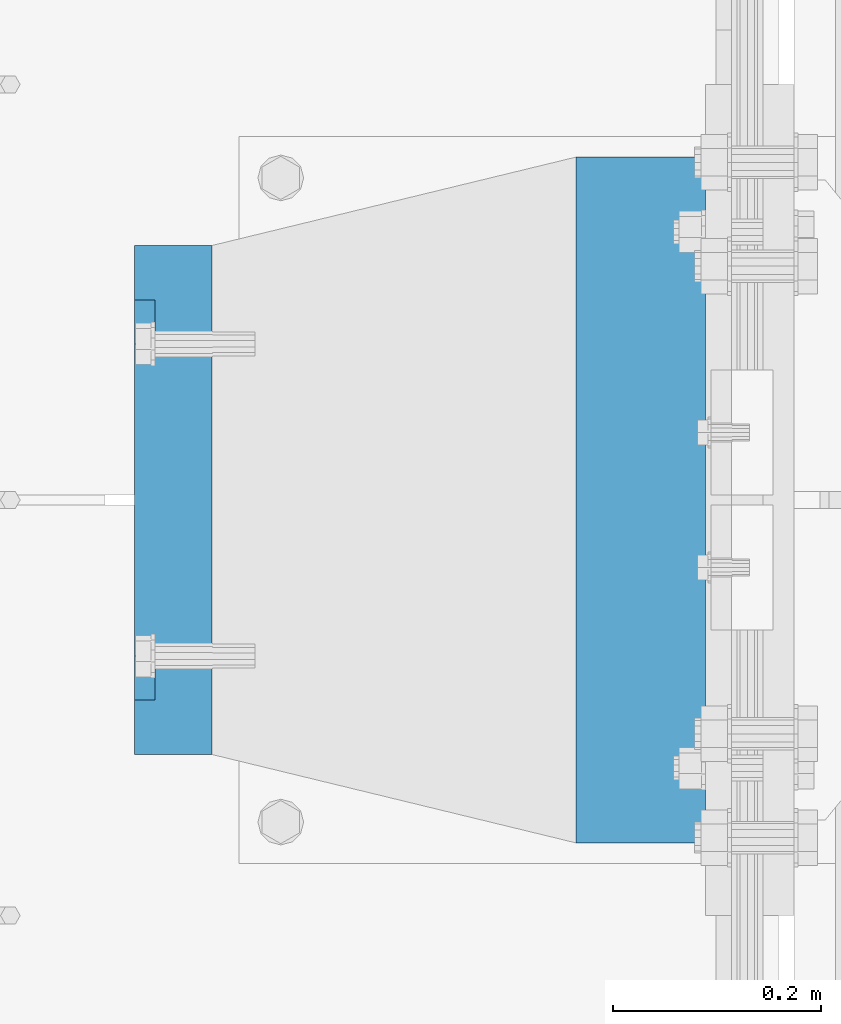
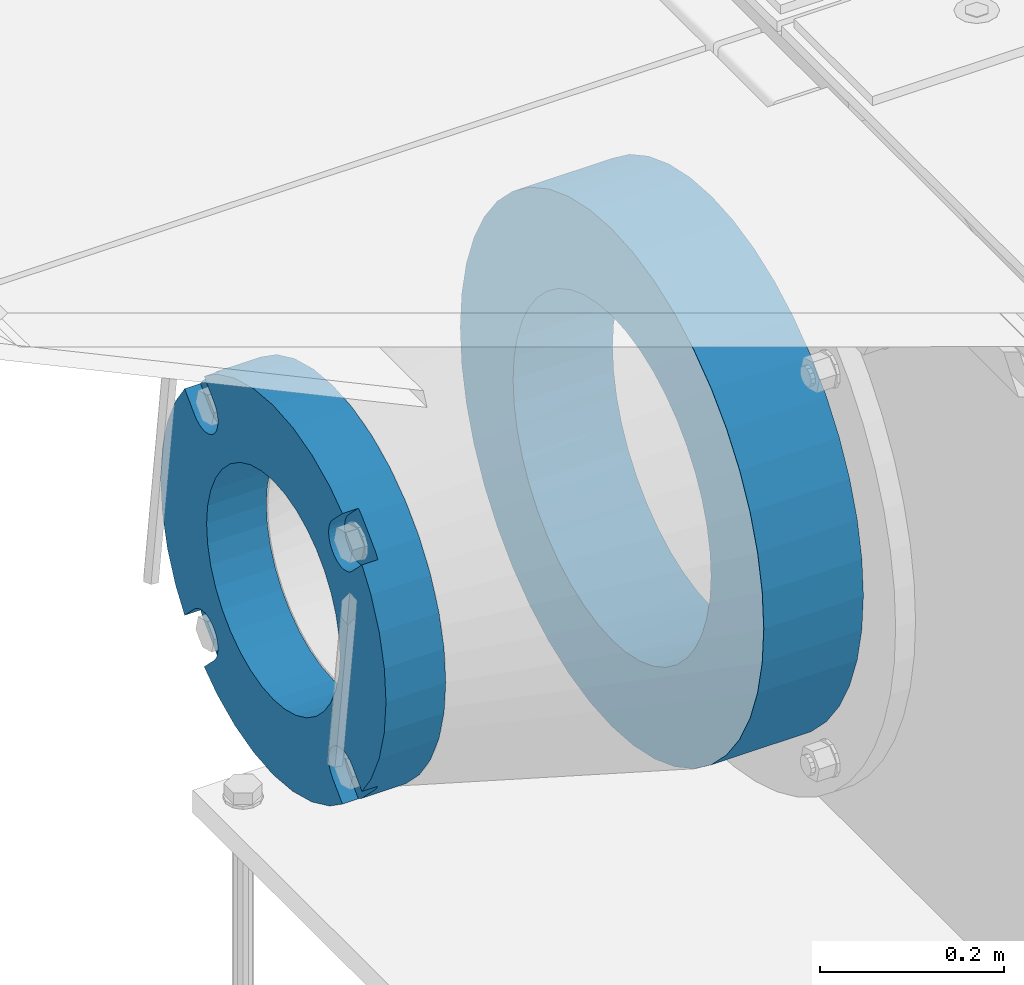
# One storey, part 143 of 240: 2 beams.
"""IFC2X3 building model written with IfcOpenShell, lengths in millimetres."""

import ifcopenshell
import ifcopenshell.guid

model = None  # the IFC model being written
_history = None  # IfcOwnerHistory: only IFC2X3 demands one
_inside = {}  # id of a spatial element -> (the spatial element, [elements in it])
_under = {}  # id of a project, library or spatial element -> (it, [spatial elements below it])
_declared = {}  # id of a project -> (the project, [libraries it declares])
_typed = {}  # id of a type object -> (the type object, [elements of that type])
_made_of = {}  # id of a material, layer set ... -> (it, [elements and type objects made of it])


def new_model(schema):
    """Start an empty IFC model of exactly this schema.

    Asked for "IFC4X3", IfcOpenShell would pick the latest addendum, in which some entities
    have other attributes; the version numbers below select the first issue.
    IFC2X3 requires an IfcOwnerHistory on every rooted entity: one is made here for all.
    """
    global model, _history
    if schema == "IFC4X3":
        model = ifcopenshell.file(schema_version=(4, 3, 0, 0))
    else:
        model = ifcopenshell.file(schema=schema)
    _inside.clear()
    _under.clear()
    _declared.clear()
    _typed.clear()
    _made_of.clear()
    _history = None
    if model.schema == "IFC2X3":
        org = make("IfcOrganization", Name="unknown")
        user = make(
            "IfcPersonAndOrganization",
            ThePerson=make("IfcPerson", FamilyName="unknown"),
            TheOrganization=org,
        )
        app = make(
            "IfcApplication",
            ApplicationDeveloper=org,
            Version="unknown",
            ApplicationFullName="unknown",
            ApplicationIdentifier="unknown",
        )
        _history = make(
            "IfcOwnerHistory",
            OwningUser=user,
            OwningApplication=app,
            ChangeAction="ADDED",
            CreationDate=0,
        )
    return model


def make(cls, **values):
    """One entity of the class cls with the attributes given. An attribute that is None is left unset."""
    return model.create_entity(
        cls, **{name: value for name, value in values.items() if value is not None}
    )


def rooted(cls, **values):
    """An entity with a GlobalId (a new one), such as an element, a storey or a relation."""
    return make(cls, GlobalId=ifcopenshell.guid.new(), OwnerHistory=_history, **values)


def si_unit(unit_type, name, prefix=None):
    """IfcSIUnit, for example si_unit("LENGTHUNIT", "METRE", prefix="MILLI")."""
    return make("IfcSIUnit", UnitType=unit_type, Prefix=prefix, Name=name)


def assignment(units):
    """IfcUnitAssignment: the units of a project."""
    return None if units is None else make("IfcUnitAssignment", Units=units)


def point(xyz):
    """IfcCartesianPoint."""
    return None if xyz is None else make("IfcCartesianPoint", Coordinates=xyz)


def direction(xyz):
    """IfcDirection."""
    return None if xyz is None else make("IfcDirection", DirectionRatios=xyz)


def frame(location, z_axis=None, x_axis=None):
    """IfcAxis2Placement3D, a coordinate frame: its origin and axes. An axis left out is left unset."""
    return make(
        "IfcAxis2Placement3D",
        Location=point(location),
        Axis=direction(z_axis),
        RefDirection=direction(x_axis),
    )


def origin_with_axes():
    """The frame at (0, 0, 0) with the z axis (0, 0, 1) and the x axis (1, 0, 0) written out."""
    return frame((0.0, 0.0, 0.0), z_axis=(0.0, 0.0, 1.0), x_axis=(1.0, 0.0, 0.0))


def place(relative_to, where):
    """IfcLocalPlacement: puts the frame where relative to a parent placement (None: the world)."""
    return make(
        "IfcLocalPlacement", PlacementRelTo=relative_to, RelativePlacement=where
    )


def context(
    kind, dimensions, precision=None, world=None, true_north=None, identifier=None
):
    """IfcGeometricRepresentationContext, for example the 3D "Model" context."""
    return make(
        "IfcGeometricRepresentationContext",
        ContextIdentifier=identifier,
        ContextType=kind,
        CoordinateSpaceDimension=dimensions,
        Precision=precision,
        WorldCoordinateSystem=world,
        TrueNorth=true_north,
    )


def subcontext(parent, identifier, kind, view, scale=None):
    """IfcGeometricRepresentationSubContext, for example "Body" below "Model"."""
    return make(
        "IfcGeometricRepresentationSubContext",
        ContextIdentifier=identifier,
        ContextType=kind,
        ParentContext=parent,
        TargetScale=scale,
        TargetView=view,
    )


def project(units=None, contexts=None):
    """IfcProject with its units and contexts."""
    return rooted(
        "IfcProject",
        Name="project",
        RepresentationContexts=contexts,
        UnitsInContext=assignment(units),
    )


def spatial(cls, under=None, at=None, **own):
    """A site, building, storey or space (cls), placed at a placement, below another one or the project."""
    s = rooted(cls, ObjectPlacement=at, **own)
    if under is not None:
        _under.setdefault(under.id(), (under, []))[1].append(s)
    return s


def faces_of(points, faces, orient=None, outer=None):
    """IfcFace entities. A face is a list of loops; a loop is a list of indices into points, from 0.

    orient and outer hold one flag for each loop. By default every Orientation is true, the
    first loop of a face is its IfcFaceOuterBound and the others are IfcFaceBound.
    """
    made = []
    for i, loops in enumerate(faces):
        bounds = []
        for j, loop in enumerate(loops):
            is_outer = j == 0 if outer is None else outer[i][j]
            bounds.append(
                make(
                    "IfcFaceOuterBound" if is_outer else "IfcFaceBound",
                    Bound=make("IfcPolyLoop", Polygon=[points[k] for k in loop]),
                    Orientation=True if orient is None else orient[i][j],
                )
            )
        made.append(make("IfcFace", Bounds=bounds))
    return made


def faceted_brep(points, faces, orient=None, outer=None, voids=None):
    """IfcFacetedBrep: a solid bounded by flat faces; with voids (closed shells), ...WithVoids."""
    shared = [point(p) for p in points]
    hull = make("IfcClosedShell", CfsFaces=faces_of(shared, faces, orient, outer))
    if voids is None:
        return make("IfcFacetedBrep", Outer=hull)
    return make(
        "IfcFacetedBrepWithVoids",
        Outer=hull,
        Voids=[
            make(cls, CfsFaces=faces_of(shared, fs, o, b)) for cls, fs, o, b in voids
        ],
    )


def shape(context_of_items, identifier, shape_type, items):
    """IfcShapeRepresentation: the items that make up one representation, for example the "Body"."""
    return make(
        "IfcShapeRepresentation",
        ContextOfItems=context_of_items,
        RepresentationIdentifier=identifier,
        RepresentationType=shape_type,
        Items=items,
    )


def material(Name=None, Category=None):
    """IfcMaterial."""
    return make("IfcMaterial", Name=Name, Category=Category)


def made_of(thing, what):
    """Note that an element or type object is made of a material, layer set ...; save() writes the relation."""
    if what is not None:
        _made_of.setdefault(what.id(), (what, []))[1].append(thing)
    return thing


def type_object(cls, material=None, **own):
    """A type object (cls), such as IfcWallType, which elements share."""
    return made_of(rooted(cls, **own), material)


def element(
    cls,
    number,
    at=None,
    inside=None,
    cuts=None,
    type_object=None,
    material=None,
    context=None,
    identifier="Body",
    shape_type=None,
    held_by="IfcProductDefinitionShape",
    body=None,
    shapes=None,
    **own,
):
    """One element of the class cls, such as IfcWall. Its Tag is "e" and its number.

    at: its placement. inside: the storey or other place that contains it. cuts: it is an
    opening in that element (IfcRelVoidsElement). A single representation is given by context,
    identifier, shape_type and body (its items); several are given by shapes. held_by: the class
    of the entity that holds the representations. save() writes the other relations.
    """
    e = rooted(cls, Tag="e%d" % number, ObjectPlacement=at, **own)
    if body is not None:
        shapes = [shape(context, identifier, shape_type, body)]
    if shapes is not None:
        e.Representation = make(held_by, Representations=shapes)
    if inside is not None:
        _inside.setdefault(inside.id(), (inside, []))[1].append(e)
    if cuts is not None:
        rooted(
            "IfcRelVoidsElement", RelatingBuildingElement=cuts, RelatedOpeningElement=e
        )
    if type_object is not None:
        _typed.setdefault(type_object.id(), (type_object, []))[1].append(e)
    return made_of(e, material)


def aggregate(whole, parts):
    """IfcRelAggregates: a whole, such as a stair, and the parts it consists of."""
    return rooted("IfcRelAggregates", RelatingObject=whole, RelatedObjects=parts)


def save(model, path):
    """Write the relations noted so far, then the file.

    IfcRelAggregates (storeys below a building ...), IfcRelContainedInSpatialStructure (elements
    in a storey), IfcRelDefinesByType, IfcRelAssociatesMaterial and IfcRelDeclares: one each for
    every whole, place, type object, material and project.
    """
    for whole, parts in _under.values():
        aggregate(whole, parts)
    for where, things in _inside.values():
        rooted(
            "IfcRelContainedInSpatialStructure",
            RelatedElements=things,
            RelatingStructure=where,
        )
    for kind, things in _typed.values():
        rooted("IfcRelDefinesByType", RelatedObjects=things, RelatingType=kind)
    for what, things in _made_of.values():
        rooted("IfcRelAssociatesMaterial", RelatedObjects=things, RelatingMaterial=what)
    for by, libraries in _declared.values():
        rooted("IfcRelDeclares", RelatingContext=by, RelatedDefinitions=libraries)
    model.write(path)


model = new_model("IFC2X3")

# Units and contexts
model_context = context("Model", 3, precision=1e-05, world=origin_with_axes())
body_context = subcontext(model_context, "Body", "Model", "MODEL_VIEW")
ifc_project = project(units=[si_unit("LENGTHUNIT", "METRE", prefix="MILLI"), si_unit("AREAUNIT", "SQUARE_METRE"), si_unit("VOLUMEUNIT", "CUBIC_METRE"), si_unit("MASSUNIT", "GRAM", prefix="KILO"), si_unit("TIMEUNIT", "SECOND"), si_unit("PLANEANGLEUNIT", "RADIAN"), si_unit("SOLIDANGLEUNIT", "STERADIAN"), si_unit("THERMODYNAMICTEMPERATUREUNIT", "DEGREE_CELSIUS"), si_unit("LUMINOUSINTENSITYUNIT", "LUMEN")], contexts=[model_context])

# Site, building, storey
site_placement = place(None, origin_with_axes())
site = spatial("IfcSite", under=ifc_project, at=site_placement, CompositionType="ELEMENT")
building_placement = place(site_placement, origin_with_axes())
building = spatial("IfcBuilding", under=site, at=building_placement, Name="Standard", CompositionType="ELEMENT")
storey_placement = place(building_placement, origin_with_axes())
storey = spatial("IfcBuildingStorey", under=building, at=storey_placement, Name="Undefined", CompositionType="ELEMENT", Elevation=0.0)

# Beams
ifc_material_1 = material(Name="SCN-500-E2")
beam_type_1 = type_object("IfcBeamType", PredefinedType="NOTDEFINED")
beam_1_placement = place(storey_placement, frame((41900.0, 33000.0000014662, -515.0), z_axis=(0.0, 0.0, 1.0), x_axis=(-1.0, 0.0, 0.0)))
element("IfcBeam", 1, at=beam_1_placement, inside=storey, type_object=beam_type_1, material=ifc_material_1, context=body_context, shape_type="Brep", body=[
    faceted_brep([(75.0, 192.717024793295, -150.290616455866), (75.0, 171.473395903973, -129.046987566545), (55.0, 171.473395903973, -129.046987566545), (55.0, 192.717024793288, -150.290616455862), (75.0, 167.467485559311, -125.685629673395), (55.0, 167.467485559311, -125.685629673395), (75.0, 162.938740320955, -123.070957391003), (55.0, 162.938740320955, -123.070957391003), (75.0, 158.024763821777, -121.282416213472), (55.0, 158.024763821777, -121.282416213472), (75.0, 152.874864751095, -120.374350059435), (55.0, 152.874864751095, -120.374350059435), (75.0, 147.645520186205, -120.374350059479), (55.0, 147.645520186205, -120.374350059479), (75.0, 142.495621115537, -121.282416213595), (55.0, 142.495621115537, -121.282416213595), (75.0, 137.581644616374, -123.070957391204), (55.0, 137.581644616374, -123.070957391204), (75.0, 133.052899378039, -125.685629673665), (55.0, 133.052899378039, -125.685629673665), (75.0, 129.04698903278, -129.046987566545), (55.0, 129.04698903278, -129.046987566545), (75.0, 125.685631139982, -133.05289791162), (55.0, 125.685631139982, -133.05289791162), (75.0, 123.070958857592, -137.581643149926), (55.0, 123.070958857592, -137.581643149926), (75.0, 121.28241768005, -142.49561964906), (55.0, 121.28241768005, -142.49561964906), (75.0, 120.374351525992, -147.64551871968), (55.0, 120.374351525992, -147.64551871968), (75.0, 120.374351525999, -152.874863284513), (55.0, 120.374351525999, -152.874863284513), (75.0, 121.282417680093, -158.024762355132), (55.0, 121.282417680093, -158.024762355132), (75.0, 123.070958857665, -162.938738854251), (55.0, 123.070958857665, -162.938738854251), (75.0, 125.685631140077, -167.467484092545), (55.0, 125.685631140077, -167.467484092545), (75.0, 129.04698903278, -171.473394437738), (55.0, 129.04698903278, -171.473394437738), (55.0, 150.290618180639, -192.717023585594), (75.0, 150.290618180639, -192.717023585596), (55.0, 157.482964373201, -187.68088856415), (55.0, 187.680888564151, -157.482964373202), (75.0, -192.717023585596, 150.290618180639), (75.0, -171.4733929715, 129.046987566545), (55.0, -171.4733929715, 129.046987566545), (55.0, -192.717023585596, 150.290618180638), (75.0, -167.467482626838, 125.685629673395), (55.0, -167.467482626838, 125.685629673395), (75.0, -162.938737388482, 123.070957391003), (55.0, -162.938737388482, 123.070957391003), (75.0, -158.024760889304, 121.282416213472), (55.0, -158.024760889304, 121.282416213472), (75.0, -152.874861818622, 120.374350059435), (55.0, -152.874861818622, 120.374350059435), (75.0, -147.645517253732, 120.374350059479), (55.0, -147.645517253732, 120.374350059479), (75.0, -142.495618183064, 121.282416213595), (55.0, -142.495618183064, 121.282416213595), (75.0, -137.581641683901, 123.070957391204), (55.0, -137.581641683901, 123.070957391204), (75.0, -133.052896445566, 125.685629673665), (55.0, -133.052896445566, 125.685629673665), (75.0, -129.046986100308, 129.046987566545), (55.0, -129.046986100308, 129.046987566545), (75.0, -125.68562820751, 133.05289791162), (55.0, -125.68562820751, 133.05289791162), (75.0, -123.070955925119, 137.581643149926), (55.0, -123.070955925119, 137.581643149926), (75.0, -121.282414747577, 142.49561964906), (55.0, -121.282414747577, 142.49561964906), (75.0, -120.374348593519, 147.64551871968), (55.0, -120.374348593519, 147.64551871968), (75.0, -120.374348593527, 152.874863284513), (55.0, -120.374348593527, 152.874863284513), (75.0, -121.28241474762, 158.024762355132), (55.0, -121.28241474762, 158.024762355132), (75.0, -123.070955925192, 162.938738854251), (55.0, -123.070955925192, 162.938738854251), (75.0, -125.685628207604, 167.467484092545), (55.0, -125.685628207604, 167.467484092545), (75.0, -129.046986100308, 171.473394437738), (55.0, -129.046986100308, 171.473394437738), (55.0, -150.290616455866, 192.717024793292), (75.0, -150.290616455866, 192.717024793295), (75.0, 150.290618180639, 192.717023585596), (75.0, 129.04698903278, 171.473394437739), (55.0, 129.04698903278, 171.473394437739), (55.0, 150.290618180632, 192.717023585593), (75.0, 125.685631139633, 167.467484093078), (55.0, 125.685631139633, 167.467484093078), (75.0, 123.070958857235, 162.938738854723), (55.0, 123.070958857235, 162.938738854723), (75.0, 121.282417679708, 158.024762355545), (55.0, 121.282417679708, 158.024762355545), (75.0, 120.374351525672, 152.874863284862), (55.0, 120.374351525672, 152.874863284862), (75.0, 120.374351525716, 147.645518719972), (55.0, 120.374351525716, 147.645518719972), (75.0, 121.282417679831, 142.495619649306), (55.0, 121.282417679831, 142.495619649306), (75.0, 123.070958857439, 137.581643150138), (55.0, 123.070958857439, 137.581643150138), (75.0, 125.685631139902, 133.052897911806), (55.0, 125.685631139902, 133.052897911806), (75.0, 129.04698903278, 129.046987566546), (55.0, 129.04698903278, 129.046987566546), (75.0, 133.052899377857, 125.685629673749), (55.0, 133.052899377857, 125.685629673749), (75.0, 137.581644616163, 123.070957391354), (55.0, 137.581644616163, 123.070957391354), (75.0, 142.495621115297, 121.282416213815), (55.0, 142.495621115297, 121.282416213815), (75.0, 147.645520185913, 120.374350059761), (55.0, 147.645520185913, 120.374350059761), (75.0, 152.874864750745, 120.374350059768), (55.0, 152.874864750745, 120.374350059768), (75.0, 158.02476382137, 121.282416213859), (55.0, 158.02476382137, 121.282416213859), (75.0, 162.938740320489, 123.070957391429), (55.0, 162.938740320489, 123.070957391429), (75.0, 167.46748555878, 125.685629673842), (55.0, 167.46748555878, 125.685629673842), (75.0, 171.473395903973, 129.046987566546), (55.0, 171.473395903973, 129.046987566546), (55.0, 192.717024793288, 150.290616455864), (75.0, 192.717024793295, 150.290616455871), (0.0, 212.176223927185, -122.5), (0.0, 230.224692092546, -83.7949351147888), (75.0, 230.224692092546, -83.7949351147888), (75.0, 212.176223927185, -122.5), (0.0, 241.277899487992, -42.5438035283978), (75.0, 241.277899487992, -42.5438035283978), (0.0, 245.0, 0.0), (75.0, 245.0, 0.0), (0.0, 241.277899487992, 42.543803528398), (75.0, 241.277899487992, 42.543803528398), (0.0, 230.224692092546, 83.7949351147889), (75.0, 230.224692092546, 83.7949351147889), (0.0, 212.176223927185, 122.5), (75.0, 212.176223927185, 122.5), (0.0, 187.680888564151, 157.482964373202), (55.0, 187.680888564151, 157.482964373202), (0.0, 157.482964373201, 187.68088856415), (55.0, 157.482964373201, 187.68088856415), (0.0, 122.5, 212.176223927187), (75.0, 122.5, 212.176223927187), (0.0, 83.7949351147909, 230.224692092548), (75.0, 83.7949351147909, 230.224692092548), (0.0, 42.5438035283951, 241.277899487991), (75.0, 42.5438035283951, 241.277899487991), (0.0, 0.0, 245.0), (75.0, 0.0, 245.0), (0.0, -42.5438035283951, 241.277899487991), (75.0, -42.5438035283951, 241.277899487991), (0.0, -83.7949351147909, 230.224692092548), (75.0, -83.7949351147909, 230.224692092548), (0.0, -122.5, 212.176223927187), (75.0, -122.5, 212.176223927187), (0.0, -157.482964373201, 187.68088856415), (55.0, -157.482964373201, 187.68088856415), (0.0, -187.680888564151, 157.482964373202), (55.0, -187.680888564151, 157.482964373202), (0.0, -212.176223927185, 122.5), (75.0, -212.176223927185, 122.5), (0.0, -230.224692092546, 83.7949351147888), (75.0, -230.224692092546, 83.7949351147888), (0.0, -241.277899487992, 42.5438035283979), (75.0, -241.277899487992, 42.5438035283979), (0.0, -245.0, 0.0), (75.0, -245.0, 0.0), (0.0, -187.680888564151, -157.482964373202), (0.0, -157.482964373201, -187.68088856415), (55.0, -157.482964373201, -187.68088856415), (55.0, -187.680888564151, -157.482964373202), (0.0, 83.7949351147909, -230.224692092547), (0.0, 122.5, -212.176223927187), (75.0, 122.5, -212.176223927187), (75.0, 83.7949351147909, -230.224692092547), (0.0, 42.5438035283951, -241.277899487991), (75.0, 42.5438035283951, -241.277899487991), (0.0, 0.0, -245.0), (75.0, 0.0, -245.0), (0.0, -42.5438035283951, -241.277899487991), (75.0, -42.5438035283951, -241.277899487991), (0.0, -83.7949351147909, -230.224692092548), (75.0, -83.7949351147909, -230.224692092548), (0.0, -122.5, -212.176223927187), (75.0, -122.5, -212.176223927187), (75.0, -150.290616455866, -192.717024793295), (55.0, -150.290616455866, -192.717024793296), (55.0, -129.046986100308, -171.473394437739), (55.0, -125.68562820716, -167.467484093078), (55.0, -123.070955924763, -162.938738854723), (55.0, -121.282414747235, -158.024762355545), (55.0, -120.374348593199, -152.874863284861), (55.0, -120.374348593243, -147.645518719972), (55.0, -121.282414747358, -142.495619649306), (55.0, -123.070955924966, -137.581643150138), (55.0, -125.68562820743, -133.052897911806), (55.0, -129.046986100308, -129.046987566546), (55.0, -133.052896445384, -125.685629673749), (55.0, -137.58164168369, -123.070957391354), (55.0, -142.495618182824, -121.282416213815), (55.0, -147.645517253441, -120.374350059761), (55.0, -152.874861818273, -120.374350059768), (55.0, -158.024760888897, -121.282416213859), (55.0, -162.938737388016, -123.070957391429), (55.0, -167.467482626307, -125.685629673842), (55.0, -171.4733929715, -129.046987566546), (55.0, -192.717023585596, -150.290618180638), (75.0, -129.046986100308, -171.473394437739), (75.0, -125.68562820716, -167.467484093078), (75.0, -123.070955924763, -162.938738854723), (75.0, -121.282414747235, -158.024762355545), (75.0, -120.374348593199, -152.874863284861), (75.0, -120.374348593243, -147.645518719972), (75.0, -121.282414747358, -142.495619649306), (75.0, -123.070955924966, -137.581643150138), (75.0, -125.68562820743, -133.052897911806), (75.0, -129.046986100308, -129.046987566546), (75.0, -133.052896445384, -125.685629673749), (75.0, -137.58164168369, -123.070957391354), (75.0, -142.495618182824, -121.282416213815), (75.0, -147.645517253441, -120.374350059761), (75.0, -152.874861818273, -120.374350059768), (75.0, -158.024760888897, -121.282416213859), (75.0, -162.938737388016, -123.070957391429), (75.0, -167.467482626307, -125.685629673842), (75.0, -171.4733929715, -129.046987566546), (75.0, -192.717023585596, -150.29061818064), (75.0, -212.176223927185, -122.5), (0.0, -212.176223927185, -122.5), (0.0, -230.224692092546, -83.794935114789), (75.0, -230.224692092546, -83.794935114789), (0.0, -241.277899487992, -42.5438035283979), (75.0, -241.277899487992, -42.5438035283979), (0.0, 187.680888564151, -157.482964373202), (0.0, 157.482964373201, -187.68088856415), (0.0, -142.797124186771, -25.1789857617049), (0.0, -136.25543001396, -49.592920782222), (0.0, -125.573683548741, -72.5), (0.0, -111.076444252249, -93.2042034045483), (0.0, -93.2042034045517, -111.076444252252), (0.0, -72.5, -125.573683548744), (0.0, -49.5929207822192, -136.255430013957), (0.0, -25.1789857617041, -142.79712418677), (0.0, 0.0, -145.0), (0.0, 25.1789857617041, -142.79712418677), (0.0, 49.5929207822192, -136.255430013957), (0.0, 72.5, -125.573683548744), (0.0, 93.2042034045517, -111.076444252252), (0.0, 111.076444252249, -93.2042034045483), (0.0, 125.573683548741, -72.5), (0.0, 136.25543001396, -49.592920782222), (0.0, 142.797124186771, -25.178985761705), (0.0, 145.0, 0.0), (0.0, 142.797124186771, 25.1789857617048), (0.0, 136.25543001396, 49.5929207822219), (0.0, 125.573683548741, 72.4999999999999), (0.0, 111.076444252249, 93.2042034045482), (0.0, 93.2042034045517, 111.076444252252), (0.0, 72.5, 125.573683548744), (0.0, 49.5929207822192, 136.255430013957), (0.0, 25.1789857617041, 142.79712418677), (0.0, 0.0, 145.0), (0.0, -25.1789857617041, 142.79712418677), (0.0, -49.5929207822192, 136.255430013957), (0.0, -72.5, 125.573683548744), (0.0, -93.2042034045517, 111.076444252252), (0.0, -111.076444252249, 93.2042034045483), (0.0, -125.573683548741, 72.5000000000001), (0.0, -136.25543001396, 49.5929207822221), (0.0, -142.797124186771, 25.1789857617049), (0.0, -145.0, 0.0), (75.0, -145.0, 0.0), (75.0, -142.797124186771, -25.1789857617049), (75.0, -136.25543001396, -49.592920782222), (75.0, -125.573683548741, -72.5), (75.0, -111.076444252249, -93.2042034045483), (75.0, -93.2042034045517, -111.076444252252), (75.0, -72.5, -125.573683548744), (75.0, -49.5929207822192, -136.255430013957), (75.0, -25.1789857617041, -142.79712418677), (75.0, 0.0, -145.0), (75.0, 25.1789857617041, -142.79712418677), (75.0, 49.5929207822192, -136.255430013957), (75.0, 72.5, -125.573683548744), (75.0, 93.2042034045517, -111.076444252252), (75.0, 111.076444252249, -93.2042034045483), (75.0, 125.573683548741, -72.5), (75.0, 136.25543001396, -49.592920782222), (75.0, 142.797124186771, -25.178985761705), (75.0, 145.0, 0.0), (75.0, 142.797124186771, 25.1789857617048), (75.0, 136.25543001396, 49.5929207822219), (75.0, 125.573683548741, 72.4999999999999), (75.0, 111.076444252249, 93.2042034045482), (75.0, 93.2042034045517, 111.076444252252), (75.0, 72.5, 125.573683548744), (75.0, 49.5929207822192, 136.255430013957), (75.0, 25.1789857617041, 142.79712418677), (75.0, 0.0, 145.0), (75.0, -25.1789857617041, 142.79712418677), (75.0, -49.5929207822192, 136.255430013957), (75.0, -72.5, 125.573683548744), (75.0, -93.2042034045517, 111.076444252252), (75.0, -111.076444252249, 93.2042034045483), (75.0, -125.573683548741, 72.5000000000001), (75.0, -136.25543001396, 49.5929207822221), (75.0, -142.797124186771, 25.1789857617049)], [[[0, 1, 2, 3]], [[4, 5, 2, 1]], [[6, 7, 5, 4]], [[8, 9, 7, 6]], [[10, 11, 9, 8]], [[12, 13, 11, 10]], [[14, 15, 13, 12]], [[16, 17, 15, 14]], [[18, 19, 17, 16]], [[20, 21, 19, 18]], [[22, 23, 21, 20]], [[24, 25, 23, 22]], [[26, 27, 25, 24]], [[28, 29, 27, 26]], [[30, 31, 29, 28]], [[32, 33, 31, 30]], [[34, 35, 33, 32]], [[36, 37, 35, 34]], [[38, 39, 37, 36]], [[40, 39, 38, 41]], [[42, 43, 3, 2, 5, 7, 9, 11, 13, 15, 17, 19, 21, 23, 25, 27, 29, 31, 33, 35, 37, 39, 40]], [[44, 45, 46, 47]], [[48, 49, 46, 45]], [[50, 51, 49, 48]], [[52, 53, 51, 50]], [[54, 55, 53, 52]], [[56, 57, 55, 54]], [[58, 59, 57, 56]], [[60, 61, 59, 58]], [[62, 63, 61, 60]], [[64, 65, 63, 62]], [[66, 67, 65, 64]], [[68, 69, 67, 66]], [[70, 71, 69, 68]], [[72, 73, 71, 70]], [[74, 75, 73, 72]], [[76, 77, 75, 74]], [[78, 79, 77, 76]], [[80, 81, 79, 78]], [[82, 83, 81, 80]], [[84, 83, 82, 85]], [[86, 87, 88, 89]], [[90, 91, 88, 87]], [[92, 93, 91, 90]], [[94, 95, 93, 92]], [[96, 97, 95, 94]], [[98, 99, 97, 96]], [[100, 101, 99, 98]], [[102, 103, 101, 100]], [[104, 105, 103, 102]], [[106, 107, 105, 104]], [[108, 109, 107, 106]], [[110, 111, 109, 108]], [[112, 113, 111, 110]], [[114, 115, 113, 112]], [[116, 117, 115, 114]], [[118, 119, 117, 116]], [[120, 121, 119, 118]], [[122, 123, 121, 120]], [[124, 125, 123, 122]], [[126, 125, 124, 127]], [[128, 129, 130, 131]], [[129, 132, 133, 130]], [[132, 134, 135, 133]], [[134, 136, 137, 135]], [[136, 138, 139, 137]], [[138, 140, 141, 139]], [[127, 141, 140, 142, 143, 126]], [[142, 144, 145, 143]], [[89, 88, 91, 93, 95, 97, 99, 101, 103, 105, 107, 109, 111, 113, 115, 117, 119, 121, 123, 125, 126, 143, 145]], [[144, 146, 147, 86, 89, 145]], [[146, 148, 149, 147]], [[148, 150, 151, 149]], [[150, 152, 153, 151]], [[152, 154, 155, 153]], [[154, 156, 157, 155]], [[156, 158, 159, 157]], [[85, 159, 158, 160, 161, 84]], [[160, 162, 163, 161]], [[47, 46, 49, 51, 53, 55, 57, 59, 61, 63, 65, 67, 69, 71, 73, 75, 77, 79, 81, 83, 84, 161, 163]], [[162, 164, 165, 44, 47, 163]], [[164, 166, 167, 165]], [[166, 168, 169, 167]], [[168, 170, 171, 169]], [[172, 173, 174, 175]], [[176, 177, 178, 179]], [[180, 176, 179, 181]], [[182, 180, 181, 183]], [[184, 182, 183, 185]], [[186, 184, 185, 187]], [[188, 186, 187, 189]], [[173, 188, 189, 190, 191, 174]], [[175, 174, 191, 192, 193, 194, 195, 196, 197, 198, 199, 200, 201, 202, 203, 204, 205, 206, 207, 208, 209, 210, 211]], [[190, 212, 192, 191]], [[213, 193, 192, 212]], [[214, 194, 193, 213]], [[215, 195, 194, 214]], [[216, 196, 195, 215]], [[217, 197, 196, 216]], [[218, 198, 197, 217]], [[219, 199, 198, 218]], [[220, 200, 199, 219]], [[221, 201, 200, 220]], [[222, 202, 201, 221]], [[223, 203, 202, 222]], [[224, 204, 203, 223]], [[225, 205, 204, 224]], [[226, 206, 205, 225]], [[227, 207, 206, 226]], [[228, 208, 207, 227]], [[229, 209, 208, 228]], [[230, 210, 209, 229]], [[211, 210, 230, 231]], [[232, 233, 172, 175, 211, 231]], [[234, 233, 232, 235]], [[236, 234, 235, 237]], [[170, 236, 237, 171]], [[168, 166, 164, 162, 160, 158, 156, 154, 152, 150, 148, 146, 144, 142, 140, 138, 136, 134, 132, 129, 128, 238, 239, 177, 176, 180, 182, 184, 186, 188, 173, 172, 233, 234, 236, 170], [240, 241, 242, 243, 244, 245, 246, 247, 248, 249, 250, 251, 252, 253, 254, 255, 256, 257, 258, 259, 260, 261, 262, 263, 264, 265, 266, 267, 268, 269, 270, 271, 272, 273, 274, 275]], [[240, 275, 276, 277]], [[241, 240, 277, 278]], [[242, 241, 278, 279]], [[243, 242, 279, 280]], [[244, 243, 280, 281]], [[245, 244, 281, 282]], [[246, 245, 282, 283]], [[247, 246, 283, 284]], [[248, 247, 284, 285]], [[249, 248, 285, 286]], [[250, 249, 286, 287]], [[251, 250, 287, 288]], [[252, 251, 288, 289]], [[253, 252, 289, 290]], [[254, 253, 290, 291]], [[255, 254, 291, 292]], [[256, 255, 292, 293]], [[257, 256, 293, 294]], [[258, 257, 294, 295]], [[259, 258, 295, 296]], [[260, 259, 296, 297]], [[261, 260, 297, 298]], [[262, 261, 298, 299]], [[263, 262, 299, 300]], [[264, 263, 300, 301]], [[265, 264, 301, 302]], [[266, 265, 302, 303]], [[267, 266, 303, 304]], [[268, 267, 304, 305]], [[269, 268, 305, 306]], [[270, 269, 306, 307]], [[271, 270, 307, 308]], [[272, 271, 308, 309]], [[273, 272, 309, 310]], [[274, 273, 310, 311]], [[275, 274, 311, 276]], [[24, 22, 20, 18, 16, 14, 12, 10, 8, 6, 4, 1, 0, 131, 130, 133, 135, 137, 139, 141, 127, 124, 122, 120, 118, 116, 114, 112, 110, 108, 106, 104, 102, 100, 98, 96, 94, 92, 90, 87, 86, 147, 149, 151, 153, 155, 157, 159, 85, 82, 80, 78, 76, 74, 72, 70, 68, 66, 64, 62, 60, 58, 56, 54, 52, 50, 48, 45, 44, 165, 167, 169, 171, 237, 235, 232, 231, 230, 229, 228, 227, 226, 225, 224, 223, 222, 221, 220, 219, 218, 217, 216, 215, 214, 213, 212, 190, 189, 187, 185, 183, 181, 179, 178, 41, 38, 36, 34, 32, 30, 28, 26], [310, 309, 308, 307, 306, 305, 304, 303, 302, 301, 300, 299, 298, 297, 296, 295, 294, 293, 292, 291, 290, 289, 288, 287, 286, 285, 284, 283, 282, 281, 280, 279, 278, 277, 276, 311]], [[238, 128, 131, 0, 3, 43]], [[239, 238, 43, 42]], [[178, 177, 239, 42, 40, 41]]]),
])
ifc_material_2 = material(Name="STEEL/S355N")
beam_type_2 = type_object("IfcBeamType", PredefinedType="NOTDEFINED")
beam_2_placement = place(storey_placement, frame((42375.0, 33000.0, -515.0), z_axis=(0.0, 0.0, 1.0), x_axis=(-1.0, 0.0, 0.0)))
element("IfcBeam", 2, at=beam_2_placement, inside=storey, type_object=beam_type_2, material=ifc_material_2, context=body_context, shape_type="Brep", body=[
    faceted_brep([(0.0, -215.0, 0.0), (0.0, -212.811610004399, 30.5976902287563), (125.0, -212.811610004399, 30.5976902287563), (125.0, -215.0, 0.0), (0.0, -206.290989327113, 60.5724997209074), (125.0, -206.290989327113, 60.5724997209074), (0.0, -195.570879001221, 89.3142277954056), (125.0, -195.570879001221, 89.3142277954056), (0.0, -180.869509558703, 116.237775752953), (125.0, -180.869509558703, 116.237775752953), (0.0, -162.486158486165, 140.795057798236), (125.0, -162.486158486165, 140.795057798236), (0.0, -140.795057798234, 162.486158486165), (125.0, -140.795057798234, 162.486158486165), (0.0, -116.237775752954, 180.869509558704), (125.0, -116.237775752954, 180.869509558704), (0.0, -89.314227795403, 195.570879001222), (125.0, -89.314227795403, 195.570879001222), (0.0, -60.5724997209109, 206.290989327117), (125.0, -60.5724997209109, 206.290989327117), (0.0, -30.5976902287584, 212.811610004401), (125.0, -30.5976902287584, 212.811610004401), (0.0, 0.0, 215.0), (125.0, 0.0, 215.0), (0.0, 30.5976902287584, 212.811610004401), (125.0, 30.5976902287584, 212.811610004401), (0.0, 60.5724997209109, 206.290989327117), (125.0, 60.5724997209109, 206.290989327117), (0.0, 89.314227795403, 195.570879001221), (125.0, 89.314227795403, 195.570879001221), (0.0, 116.237775752954, 180.869509558704), (125.0, 116.237775752954, 180.869509558704), (0.0, 140.795057798234, 162.486158486165), (125.0, 140.795057798234, 162.486158486165), (0.0, 162.486158486165, 140.795057798236), (125.0, 162.486158486165, 140.795057798236), (0.0, 180.869509558703, 116.237775752953), (125.0, 180.869509558703, 116.237775752953), (0.0, 195.570879001221, 89.3142277954056), (125.0, 195.570879001221, 89.3142277954056), (0.0, 206.290989327113, 60.5724997209073), (125.0, 206.290989327113, 60.5724997209073), (0.0, 212.811610004399, 30.5976902287563), (125.0, 212.811610004399, 30.5976902287563), (0.0, 215.0, 0.0), (125.0, 215.0, 0.0), (0.0, 212.811610004399, -30.5976902287563), (125.0, 212.811610004399, -30.5976902287563), (0.0, 206.290989327113, -60.5724997209073), (125.0, 206.290989327113, -60.5724997209073), (0.0, 195.570879001221, -89.3142277954056), (125.0, 195.570879001221, -89.3142277954056), (0.0, 180.869509558703, -116.237775752954), (125.0, 180.869509558703, -116.237775752954), (0.0, 162.486158486165, -140.795057798236), (125.0, 162.486158486165, -140.795057798236), (0.0, 140.795057798234, -162.486158486166), (125.0, 140.795057798234, -162.486158486166), (0.0, 116.237775752954, -180.869509558704), (125.0, 116.237775752954, -180.869509558704), (0.0, 89.314227795403, -195.570879001221), (125.0, 89.314227795403, -195.570879001221), (0.0, 60.5724997209109, -206.290989327117), (125.0, 60.5724997209109, -206.290989327117), (0.0, 30.5976902287584, -212.811610004401), (125.0, 30.5976902287584, -212.811610004401), (0.0, 0.0, -215.0), (125.0, 0.0, -215.0), (0.0, -30.5976902287584, -212.811610004401), (125.0, -30.5976902287584, -212.811610004401), (0.0, -60.5724997209109, -206.290989327117), (125.0, -60.5724997209109, -206.290989327117), (0.0, -89.314227795403, -195.570879001221), (125.0, -89.314227795403, -195.570879001221), (0.0, -116.237775752954, -180.869509558704), (125.0, -116.237775752954, -180.869509558704), (0.0, -140.795057798234, -162.486158486166), (125.0, -140.795057798234, -162.486158486166), (0.0, -162.486158486165, -140.795057798236), (125.0, -162.486158486165, -140.795057798236), (0.0, -180.869509558703, -116.237775752953), (125.0, -180.869509558703, -116.237775752953), (0.0, -195.570879001221, -89.3142277954056), (125.0, -195.570879001221, -89.3142277954056), (0.0, -206.290989327113, -60.5724997209073), (125.0, -206.290989327113, -60.5724997209073), (0.0, -212.811610004399, -30.5976902287563), (125.0, -212.811610004399, -30.5976902287563), (0.0, -330.0, 0.0), (0.0, -326.641075820706, -46.9638966301842), (125.0, -326.641075820706, -46.9638966301842), (125.0, -330.0, 0.0), (0.0, -316.632681292787, -92.9717437576718), (125.0, -316.632681292787, -92.9717437576718), (0.0, -300.178558466992, -137.086954290623), (125.0, -300.178558466992, -137.086954290623), (0.0, -277.613665834288, -178.411469760347), (125.0, -277.613665834288, -178.411469760347), (0.0, -249.397359536903, -216.104042201944), (125.0, -249.397359536903, -216.104042201944), (0.0, -216.104042201943, -249.397359536905), (125.0, -216.104042201943, -249.397359536905), (0.0, -178.411469760344, -277.61366583429), (125.0, -178.411469760344, -277.61366583429), (0.0, -137.086954290622, -300.178558466991), (125.0, -137.086954290622, -300.178558466991), (0.0, -92.9717437576692, -316.632681292784), (125.0, -92.9717437576692, -316.632681292784), (0.0, -46.9638966301864, -326.641075820708), (125.0, -46.9638966301864, -326.641075820708), (0.0, 0.0, -330.0), (125.0, 0.0, -330.0), (0.0, 46.9638966301864, -326.641075820708), (125.0, 46.9638966301864, -326.641075820708), (0.0, 92.9717437576692, -316.632681292784), (125.0, 92.9717437576692, -316.632681292784), (0.0, 137.086954290622, -300.178558466991), (125.0, 137.086954290622, -300.178558466991), (0.0, 178.411469760344, -277.61366583429), (125.0, 178.411469760344, -277.61366583429), (0.0, 216.104042201943, -249.397359536905), (125.0, 216.104042201943, -249.397359536905), (0.0, 249.397359536903, -216.104042201944), (125.0, 249.397359536903, -216.104042201944), (0.0, 277.613665834288, -178.411469760347), (125.0, 277.613665834288, -178.411469760347), (0.0, 300.178558466992, -137.086954290623), (125.0, 300.178558466992, -137.086954290623), (0.0, 316.632681292787, -92.9717437576717), (125.0, 316.632681292787, -92.9717437576717), (0.0, 326.641075820706, -46.9638966301841), (125.0, 326.641075820706, -46.9638966301841), (0.0, 330.0, 0.0), (125.0, 330.0, 0.0), (0.0, 326.641075820706, 46.9638966301841), (125.0, 326.641075820706, 46.9638966301841), (0.0, 316.632681292787, 92.9717437576718), (125.0, 316.632681292787, 92.9717437576718), (0.0, 300.178558466992, 137.086954290622), (125.0, 300.178558466992, 137.086954290622), (0.0, 277.613665834288, 178.411469760347), (125.0, 277.613665834288, 178.411469760347), (0.0, 249.397359536903, 216.104042201944), (125.0, 249.397359536903, 216.104042201944), (0.0, 216.104042201943, 249.397359536905), (125.0, 216.104042201943, 249.397359536905), (0.0, 178.411469760344, 277.61366583429), (125.0, 178.411469760344, 277.61366583429), (0.0, 137.086954290622, 300.178558466991), (125.0, 137.086954290622, 300.178558466991), (0.0, 92.9717437576692, 316.632681292784), (125.0, 92.9717437576692, 316.632681292784), (0.0, 46.9638966301864, 326.641075820708), (125.0, 46.9638966301864, 326.641075820708), (0.0, 0.0, 330.0), (125.0, 0.0, 330.0), (0.0, -46.9638966301864, 326.641075820708), (125.0, -46.9638966301864, 326.641075820708), (0.0, -92.9717437576692, 316.632681292784), (125.0, -92.9717437576692, 316.632681292784), (0.0, -137.086954290622, 300.178558466991), (125.0, -137.086954290622, 300.178558466991), (0.0, -178.411469760344, 277.61366583429), (125.0, -178.411469760344, 277.61366583429), (0.0, -216.104042201943, 249.397359536905), (125.0, -216.104042201943, 249.397359536905), (0.0, -249.397359536903, 216.104042201944), (125.0, -249.397359536903, 216.104042201944), (0.0, -277.613665834288, 178.411469760347), (125.0, -277.613665834288, 178.411469760347), (0.0, -300.178558466992, 137.086954290623), (125.0, -300.178558466992, 137.086954290623), (0.0, -316.632681292787, 92.9717437576718), (125.0, -316.632681292787, 92.9717437576718), (0.0, -326.641075820706, 46.9638966301841), (125.0, -326.641075820706, 46.9638966301841)], [[[0, 1, 2, 3]], [[1, 4, 5, 2]], [[4, 6, 7, 5]], [[6, 8, 9, 7]], [[8, 10, 11, 9]], [[10, 12, 13, 11]], [[12, 14, 15, 13]], [[14, 16, 17, 15]], [[16, 18, 19, 17]], [[18, 20, 21, 19]], [[20, 22, 23, 21]], [[22, 24, 25, 23]], [[24, 26, 27, 25]], [[26, 28, 29, 27]], [[28, 30, 31, 29]], [[30, 32, 33, 31]], [[32, 34, 35, 33]], [[34, 36, 37, 35]], [[36, 38, 39, 37]], [[38, 40, 41, 39]], [[40, 42, 43, 41]], [[42, 44, 45, 43]], [[44, 46, 47, 45]], [[46, 48, 49, 47]], [[48, 50, 51, 49]], [[50, 52, 53, 51]], [[52, 54, 55, 53]], [[54, 56, 57, 55]], [[56, 58, 59, 57]], [[58, 60, 61, 59]], [[60, 62, 63, 61]], [[62, 64, 65, 63]], [[64, 66, 67, 65]], [[66, 68, 69, 67]], [[68, 70, 71, 69]], [[70, 72, 73, 71]], [[72, 74, 75, 73]], [[74, 76, 77, 75]], [[76, 78, 79, 77]], [[78, 80, 81, 79]], [[80, 82, 83, 81]], [[82, 84, 85, 83]], [[84, 86, 87, 85]], [[86, 0, 3, 87]], [[88, 89, 90, 91]], [[89, 92, 93, 90]], [[92, 94, 95, 93]], [[94, 96, 97, 95]], [[96, 98, 99, 97]], [[98, 100, 101, 99]], [[100, 102, 103, 101]], [[102, 104, 105, 103]], [[104, 106, 107, 105]], [[106, 108, 109, 107]], [[108, 110, 111, 109]], [[110, 112, 113, 111]], [[112, 114, 115, 113]], [[114, 116, 117, 115]], [[116, 118, 119, 117]], [[118, 120, 121, 119]], [[120, 122, 123, 121]], [[122, 124, 125, 123]], [[124, 126, 127, 125]], [[126, 128, 129, 127]], [[128, 130, 131, 129]], [[130, 132, 133, 131]], [[132, 134, 135, 133]], [[134, 136, 137, 135]], [[136, 138, 139, 137]], [[138, 140, 141, 139]], [[140, 142, 143, 141]], [[142, 144, 145, 143]], [[144, 146, 147, 145]], [[146, 148, 149, 147]], [[148, 150, 151, 149]], [[150, 152, 153, 151]], [[152, 154, 155, 153]], [[154, 156, 157, 155]], [[156, 158, 159, 157]], [[158, 160, 161, 159]], [[160, 162, 163, 161]], [[162, 164, 165, 163]], [[164, 166, 167, 165]], [[166, 168, 169, 167]], [[168, 170, 171, 169]], [[170, 172, 173, 171]], [[172, 174, 175, 173]], [[174, 88, 91, 175]], [[93, 95, 97, 99, 101, 103, 105, 107, 109, 111, 113, 115, 117, 119, 121, 123, 125, 127, 129, 131, 133, 135, 137, 139, 141, 143, 145, 147, 149, 151, 153, 155, 157, 159, 161, 163, 165, 167, 169, 171, 173, 175, 91, 90], [5, 7, 9, 11, 13, 15, 17, 19, 21, 23, 25, 27, 29, 31, 33, 35, 37, 39, 41, 43, 45, 47, 49, 51, 53, 55, 57, 59, 61, 63, 65, 67, 69, 71, 73, 75, 77, 79, 81, 83, 85, 87, 3, 2]], [[174, 172, 170, 168, 166, 164, 162, 160, 158, 156, 154, 152, 150, 148, 146, 144, 142, 140, 138, 136, 134, 132, 130, 128, 126, 124, 122, 120, 118, 116, 114, 112, 110, 108, 106, 104, 102, 100, 98, 96, 94, 92, 89, 88], [86, 84, 82, 80, 78, 76, 74, 72, 70, 68, 66, 64, 62, 60, 58, 56, 54, 52, 50, 48, 46, 44, 42, 40, 38, 36, 34, 32, 30, 28, 26, 24, 22, 20, 18, 16, 14, 12, 10, 8, 6, 4, 1, 0]]]),
])

save(model, "model.ifc")
